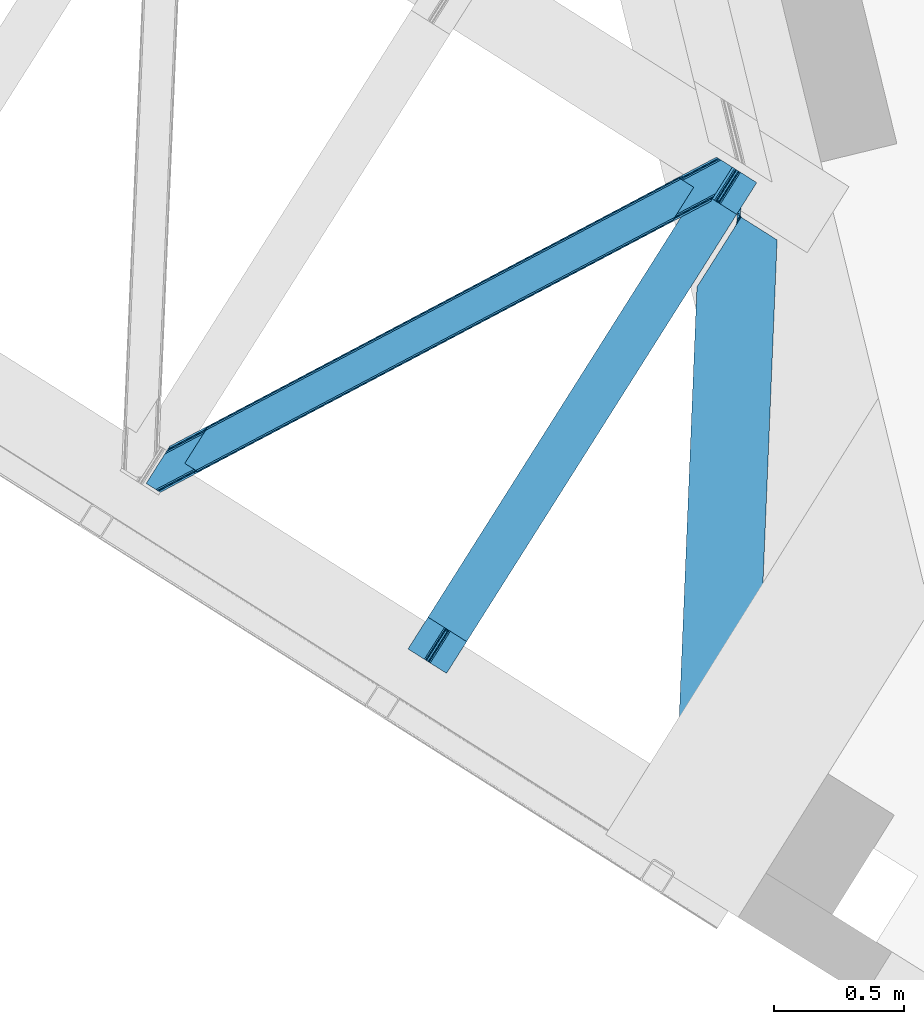
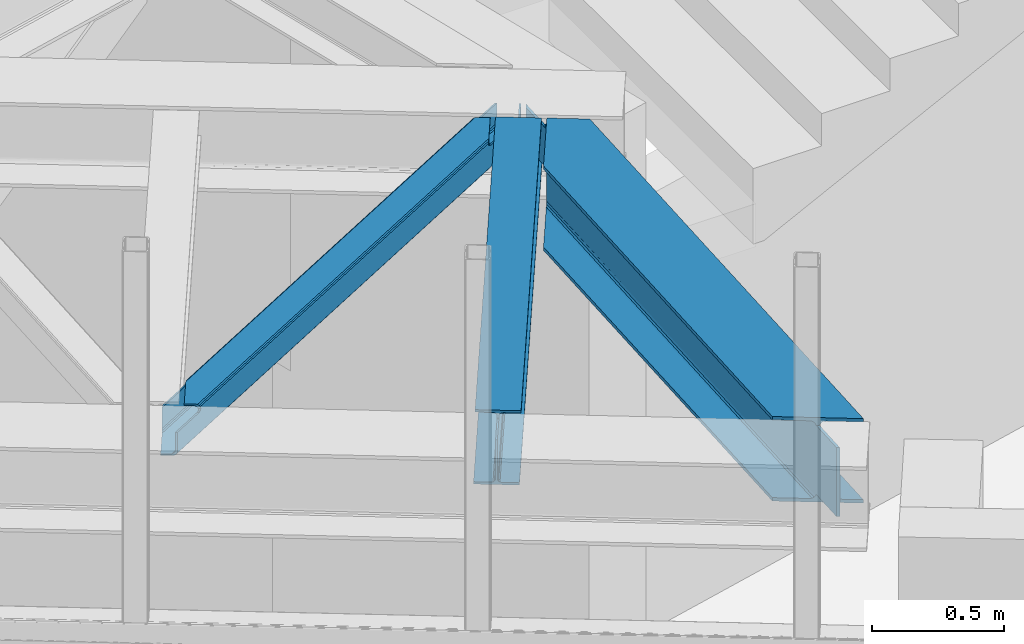
# One storey, part 50 of 66: 2 beams, 1 member.
"""IFC4 building model written with IfcOpenShell, lengths in millimetres."""

from ifc_helpers import new_model, entity, si_unit, converted_unit, derived_unit, direction, frame, origin, place, context, subcontext, project, spatial, triangles, type_object, element, save


model = new_model("IFC4")

# Units and contexts
model_context = context("Model", 3, precision=0.01, world=origin(), true_north=direction((6.12303176911189e-17, 1.0)))
plan_context = context("Plan", 3, precision=0.01, world=origin(), true_north=direction((6.12303176911189e-17, 1.0)))
body_context = subcontext(model_context, "Body", "Model", "MODEL_VIEW")
ifc_project = project(units=[si_unit("LENGTHUNIT", "METRE", prefix="MILLI"), si_unit("AREAUNIT", "SQUARE_METRE"), si_unit("VOLUMEUNIT", "CUBIC_METRE"), converted_unit("PLANEANGLEUNIT", "DEGREE", entity("IfcRatioMeasure", 0.0174532925199433), si_unit("PLANEANGLEUNIT", "RADIAN"), dimensions=[0, 0, 0, 0, 0, 0, 0]), si_unit("MASSUNIT", "GRAM", prefix="KILO"), derived_unit("MASSDENSITYUNIT", [(si_unit("MASSUNIT", "GRAM", prefix="KILO"), 1), (si_unit("LENGTHUNIT", "METRE"), -3)]), derived_unit("MOMENTOFINERTIAUNIT", [(si_unit("LENGTHUNIT", "METRE"), 4)]), si_unit("TIMEUNIT", "SECOND"), si_unit("FREQUENCYUNIT", "HERTZ"), si_unit("THERMODYNAMICTEMPERATUREUNIT", "DEGREE_CELSIUS"), derived_unit("THERMALTRANSMITTANCEUNIT", [(si_unit("MASSUNIT", "GRAM", prefix="KILO"), 1), (si_unit("THERMODYNAMICTEMPERATUREUNIT", "KELVIN"), -1), (si_unit("TIMEUNIT", "SECOND"), -3)]), derived_unit("VOLUMETRICFLOWRATEUNIT", [(si_unit("LENGTHUNIT", "METRE"), 3), (si_unit("TIMEUNIT", "SECOND"), -1)]), derived_unit("MASSFLOWRATEUNIT", [(si_unit("MASSUNIT", "GRAM", prefix="KILO"), 1), (si_unit("TIMEUNIT", "SECOND"), -1)]), derived_unit("ROTATIONALFREQUENCYUNIT", [(si_unit("TIMEUNIT", "SECOND"), -1)]), si_unit("ELECTRICCURRENTUNIT", "AMPERE"), si_unit("ELECTRICVOLTAGEUNIT", "VOLT"), si_unit("POWERUNIT", "WATT"), si_unit("FORCEUNIT", "NEWTON", prefix="KILO"), si_unit("ILLUMINANCEUNIT", "LUX"), si_unit("LUMINOUSFLUXUNIT", "LUMEN"), si_unit("LUMINOUSINTENSITYUNIT", "CANDELA"), derived_unit("USERDEFINED", [(si_unit("MASSUNIT", "GRAM", prefix="KILO"), -1), (si_unit("LENGTHUNIT", "METRE"), -2), (si_unit("TIMEUNIT", "SECOND"), 3), (si_unit("LUMINOUSFLUXUNIT", "LUMEN"), 1)]), derived_unit("LINEARVELOCITYUNIT", [(si_unit("LENGTHUNIT", "METRE"), 1), (si_unit("TIMEUNIT", "SECOND"), -1)]), si_unit("PRESSUREUNIT", "PASCAL"), derived_unit("USERDEFINED", [(si_unit("LENGTHUNIT", "METRE"), -2), (si_unit("MASSUNIT", "GRAM", prefix="KILO"), 1), (si_unit("TIMEUNIT", "SECOND"), -2)]), derived_unit("LINEARFORCEUNIT", [(si_unit("MASSUNIT", "GRAM", prefix="KILO"), 1), (si_unit("LENGTHUNIT", "METRE"), 1), (si_unit("TIMEUNIT", "SECOND"), -2), (si_unit("LENGTHUNIT", "METRE"), -1)]), derived_unit("PLANARFORCEUNIT", [(si_unit("MASSUNIT", "GRAM", prefix="KILO"), 1), (si_unit("LENGTHUNIT", "METRE"), 1), (si_unit("TIMEUNIT", "SECOND"), -2), (si_unit("LENGTHUNIT", "METRE"), -2)])], contexts=[model_context, plan_context])

# Site, building, storey
site_placement = place(None, origin())
site = spatial("IfcSite", under=ifc_project, at=site_placement, CompositionType="ELEMENT")
building_placement = place(site_placement, origin())
building = spatial("IfcBuilding", under=site, at=building_placement, CompositionType="ELEMENT")
storey_placement = place(building_placement, frame((0.0, 0.0, 19800.0)))
storey = spatial("IfcBuildingStorey", under=building, at=storey_placement, Name="06", CompositionType="ELEMENT", Elevation=19800.0)

# Beams
beam_type_1 = type_object("IfcBeamType", PredefinedType="BEAM")
beam_1_placement = place(storey_placement, frame((-1267.77, 13575.97, 3864.0)))
element("IfcBeam", 1, at=beam_1_placement, inside=storey, type_object=beam_type_1, ObjectType="Steel Beam", PredefinedType="BEAM", context=body_context, shape_type="Tessellation", body=[
    triangles([(1113.74242901802, 1855.23675842285, 232.99973144531), (1171.22194197178, 1818.90060424805, 232.99973144531), (134.557775115967, 179.105346679688, 232.99973144531), (77.078289413452, 215.441500854493, 232.99973144531), (1113.74242901802, 1855.23675842285, 244.001385498046), (77.078289413452, 215.441500854493, 244.001385498046), (1261.66156323999, 1761.72269897461, 244.001385498046), (225.001891136169, 121.928604125977, 244.001385498046), (1261.66156323999, 1761.72269897461, 232.99973144531), (225.001891136169, 121.928604125977, 232.99973144531), (1204.18659954071, 1798.06001586914, 232.99973144531), (167.522478103638, 158.264758300782, 232.99973144531), (1199.00899951458, 1801.33190917969, 231.783526611329), (1176.39499104023, 1815.62754821777, 231.783526611329), (1191.69133661985, 1805.95953369141, 223.123590087889), (1180.78569324017, 1812.85446166992, 228.313970947263), (1194.62281647921, 1804.10615844727, 228.313970947263), (1190.76869580746, 1806.54321899414, 219.000585937498), (1184.63980937004, 1810.41740112305, 219.000585937498), (1183.71717309952, 1811.00108642578, 223.123590087889), (157.958672332764, 164.310900878907, 228.313970947263), (162.344887161255, 161.536651611328, 231.783526611329), (144.121508216858, 173.06036682129, 228.313970947263), (139.730860519409, 175.832290649414, 231.783526611329), (154.104547119141, 166.747961425781, 219.000585937498), (155.027165222168, 166.164276123047, 223.123590087889), (147.975706100464, 170.622143554687, 219.000585937498), (147.053015327454, 171.206991577148, 223.123590087889), (147.982028388977, 170.400064086914, 217.00070800781), (1184.84340341091, 1810.50576782227, 217.00070800781), (1190.76235535145, 1806.76529846191, 217.00070800781), (153.900925827026, 166.659594726563, 217.00070800781), (1191.11113493443, 1807.31759033203, 214.791540527342), (1185.19218299389, 1811.05805969238, 214.791540527342), (1192.38168329, 1809.33258361816, 211.221990966795), (1186.46725051403, 1813.07421569824, 211.221990966795), (1194.28882523775, 1812.34867858887, 208.838415527342), (1188.37442879677, 1816.09031066895, 208.838415527342), (1196.54243041277, 1815.90776367188, 208.001257324217), (1190.62348301411, 1819.64823303223, 208.001257324217), (153.55218257904, 166.107302856446, 214.791540527342), (147.633212471008, 169.847772216797, 214.791540527342), (152.277042388916, 164.092309570313, 211.221990966795), (146.358217620849, 167.831616210937, 211.221990966795), (150.369964027405, 161.075051879883, 208.838415527342), (144.450993919372, 164.815521240234, 208.838415527342), (148.120828056335, 157.517129516602, 208.001257324217), (142.201930618286, 161.257598876953, 208.001257324217), (1267.74426928712, 1928.53809814453, 208.001257324217), (1261.82531823367, 1932.27856750488, 208.001257324217), (76.9144912719726, 44.8867950439453, 208.001257324217), (71.0000993728638, 48.6272644042965, 208.001257324217), (1261.82531823367, 1932.27856750488, 27.0006774902322), (71.0000993728638, 48.6272644042965, 27.0006774902322), (1267.74426928712, 1928.53809814453, 27.0006774902322), (76.9144912719726, 44.8867950439453, 27.0006774902322), (1253.4777905345, 1937.55615234375, 12.2178588867173), (1248.30474373698, 1940.82920837402, 10.9993286132813), (57.4749801635742, 57.1767425537109, 10.9993286132813), (62.6525711059569, 53.9060119628903, 12.2178588867173), (1257.86397470534, 1934.78190307617, 15.6874145507791), (67.0387859344482, 51.1317626953132, 15.6874145507791), (1260.8000060901, 1932.92969055176, 20.877795410157), (69.970220375061, 49.2783874511715, 20.877795410157), (1190.82522397041, 1977.16536254883, 10.9993286132813), (0.0, 93.5140594482418, 10.9993286132813), (1190.82522397041, 1977.16536254883, 0.0), (0.0, 93.5140594482418, 0.0), (1338.74436103106, 1883.65130310059, 0.0), (147.91916885376, 0.0, 0.0), (85.2665977478027, 39.6092102050789, 12.2178588867173), (80.8758047103881, 42.3822967529304, 15.6874145507791), (77.9443702697754, 44.2356719970703, 20.877795410157), (90.4396104812622, 36.3373168945309, 10.9993286132813), (147.91916885376, 0.0, 10.9993286132813), (1271.70561341867, 1926.03359985352, 15.6874145507791), (1276.09179787338, 1923.25935058594, 12.2178588867173), (1281.26939676404, 1919.98861999512, 10.9993286132813), (1338.74436103106, 1883.65130310059, 10.9993286132813), (1268.77413476575, 1927.88697509766, 20.877795410157)], [[1, 2, 3], [3, 4, 1], [5, 1, 4], [4, 6, 5], [7, 5, 8], [6, 8, 5], [9, 7, 10], [8, 10, 7], [11, 9, 10], [10, 12, 11], [11, 13, 14], [15, 16, 17], [13, 17, 16], [15, 18, 19], [7, 11, 5], [11, 7, 9], [2, 11, 14], [16, 15, 20], [19, 20, 15], [16, 14, 13], [2, 5, 11], [5, 2, 1], [21, 22, 23], [12, 8, 6], [10, 8, 12], [22, 12, 24], [25, 26, 27], [26, 21, 23], [23, 22, 24], [6, 3, 12], [3, 24, 12], [6, 4, 3], [23, 28, 26], [28, 27, 26], [19, 29, 27], [27, 20, 19], [19, 30, 29], [27, 28, 20], [16, 20, 23], [28, 23, 20], [14, 16, 23], [23, 24, 14], [2, 14, 3], [24, 3, 14], [25, 31, 18], [18, 26, 25], [18, 15, 26], [25, 32, 31], [15, 17, 26], [21, 26, 17], [17, 13, 22], [22, 21, 17], [13, 11, 12], [12, 22, 13], [31, 33, 34], [34, 30, 31], [18, 31, 30], [30, 19, 18], [33, 35, 34], [36, 34, 35], [35, 37, 38], [38, 36, 35], [37, 39, 38], [40, 38, 39], [41, 32, 42], [29, 42, 32], [32, 25, 27], [27, 29, 32], [43, 41, 42], [42, 44, 43], [45, 43, 46], [44, 46, 43], [47, 45, 46], [46, 48, 47], [49, 50, 39], [40, 39, 50], [47, 48, 51], [52, 51, 48], [36, 53, 54], [38, 53, 36], [50, 53, 40], [38, 40, 53], [30, 34, 42], [34, 36, 42], [44, 36, 54], [54, 46, 44], [48, 46, 54], [54, 52, 48], [44, 42, 36], [42, 29, 30], [55, 35, 56], [33, 41, 35], [37, 35, 55], [33, 31, 32], [55, 39, 37], [39, 55, 49], [56, 35, 43], [43, 35, 41], [32, 41, 33], [43, 45, 56], [47, 56, 45], [56, 47, 51], [57, 58, 59], [59, 60, 57], [61, 57, 62], [60, 62, 57], [63, 61, 62], [62, 64, 63], [53, 63, 54], [64, 54, 63], [58, 65, 66], [66, 59, 58], [65, 67, 66], [68, 66, 67], [67, 69, 68], [70, 68, 69], [71, 72, 60], [56, 64, 73], [72, 73, 62], [56, 51, 54], [74, 68, 70], [70, 75, 74], [74, 71, 59], [60, 72, 62], [64, 56, 54], [52, 54, 51], [64, 62, 73], [68, 74, 59], [60, 59, 71], [66, 68, 59], [76, 77, 57], [78, 69, 67], [79, 69, 78], [77, 78, 58], [55, 80, 63], [80, 76, 61], [49, 55, 53], [61, 76, 57], [67, 58, 78], [58, 57, 77], [67, 65, 58], [63, 53, 55], [53, 50, 49], [61, 63, 80], [80, 55, 73], [56, 73, 55], [76, 80, 73], [73, 72, 76], [77, 76, 71], [72, 71, 76], [78, 77, 71], [71, 74, 78], [79, 78, 75], [74, 75, 78], [69, 79, 70], [75, 70, 79]]),
])
beam_type_2 = type_object("IfcBeamType", PredefinedType="BEAM")
beam_2_placement = place(storey_placement, frame((-235.75, 12925.28, 3716.0)))
element("IfcBeam", 2, at=beam_2_placement, inside=storey, type_object=beam_type_2, ObjectType="Steel Beam", PredefinedType="BEAM", context=body_context, shape_type="Tessellation", body=[
    triangles([(233.281526336074, 2423.1276763916, 356.001525878906), (244.678622616827, 2415.92462768555, 356.001525878906), (238.341486717761, 2545.92599487305, 356.001525878906), (250.747194671631, 2565.55502929687, 356.001525878906), (245.781376549602, 2403.50561828613, 362.41043701172), (244.023252917826, 2403.74630126953, 364.221954345703), (245.537573298812, 2402.36499023438, 367.000854492188), (242.53565749079, 2405.33225097656, 362.817388916017), (244.82996353358, 2406.62286987305, 359.222259521484), (241.500046648085, 2406.43916015625, 361.83837890625), (238.207450908422, 2409.10643920898, 361.001220703125), (232.385556542873, 2414.48983154297, 359.222259521484), (231.81794237718, 2413.14689025879, 361.001220703125), (244.56884098202, 2411.01329956055, 356.838684082031), (232.990733709186, 2418.33145751953, 356.838684082031), (248.213948589563, 2400.67439575195, 367.000854492188), (231.194143527746, 2398.01176757813, 361.001220703125), (245.848223850131, 2402.17081604004, 367.79150390625), (229.080534236133, 2380.1116973877, 364.221954345703), (226.37978554666, 2371.37618408203, 367.79150390625), (246.55568203032, 2401.72316894531, 372.000549316406), (224.501758146286, 2367.80779724121, 369.407684326172), (221.500491258502, 2362.09186706543, 372.000549316406), (230.523896920681, 2389.07626647949, 361.83837890625), (230.180002690852, 2386.93221130371, 362.408111572266), (265.525510007143, 2389.72971496582, 376.000305175781), (257.313895046711, 2394.92125854492, 374.325988769531), (246.55568203032, 2401.72316894531, 392.001654052736), (250.749615490437, 2399.07100524902, 369.042590332032), (384.774951267242, 2314.34245605469, 392.001654052736), (384.774951267242, 2314.34245605469, 376.000305175781), (292.630248641968, 77.4278320312496, 392.001654052736), (292.630248641968, 77.4278320312496, 376.000305175781), (173.385328817368, 152.816253662109, 376.000305175781), (77.0741108894348, 2133.64185791016, 392.001654052736), (0.0, 262.429330444336, 392.001654052736), (216.970907637477, 2354.92835083008, 374.325988769531), (207.956919550896, 2340.67108154297, 376.000305175781), (77.0741108894348, 2133.64185791016, 376.000305175781), (119.244928908348, 187.040908813477, 376.000305175781), (0.0, 262.429330444336, 376.000305175781), (158.208139300346, 162.40869140625, 369.556512451174), (165.173679792881, 158.008959960938, 374.325988769531), (134.422118425369, 177.448471069336, 369.556512451174), (127.461097097397, 181.849365234375, 374.325988769531), (152.011397266388, 166.325894165038, 356.001525878906), (153.556270265579, 165.350372314453, 362.419738769531), (140.61885137558, 173.531268310548, 356.001525878906), (139.073923873901, 174.50795288086, 362.419738769531), (133.766217327118, 7.20304870605469, 356.001525878906), (145.163350510597, 0.0, 356.001525878906), (133.856409859657, 7.14723815917932, 354.001647949219), (238.437992171198, 2546.08063659668, 354.001647949219), (250.747194671631, 2565.55502929687, 354.001647949219), (145.07314889431, 0.0558105468753638, 354.001647949219), (250.747194671631, 2565.55502929687, 179.000701904297), (238.437992171198, 2546.08063659668, 179.000701904297), (244.730604931712, 2419.42325134277, 179.000701904297), (232.416850054264, 2399.94769592285, 179.000701904297), (244.381695905328, 2410.99585876465, 178.163543701172), (232.072493688762, 2391.52146606445, 178.163543701172), (244.088522484899, 2403.85210876465, 175.777642822268), (231.77476760745, 2384.37655334473, 175.777642822268), (243.892482148111, 2399.07914428711, 172.210418701172), (231.578761618584, 2379.60358886719, 172.210418701172), (243.822449858487, 2397.40250244141, 168.001373291016), (231.508694413304, 2377.92694702148, 168.001373291016), (133.856409859657, 7.14723815917932, 38.0000061035171), (231.508694413304, 2377.92694702148, 38.0000061035171), (145.07314889431, 0.0558105468753638, 38.0000061035171), (243.822449858487, 2397.40250244141, 38.0000061035171), (145.163350510597, 0.0, 36.0001281738296), (133.766217327118, 7.20304870605469, 36.0001281738296), (152.011397266388, 166.325894165038, 36.0001281738296), (140.61885137558, 173.531268310548, 36.0001281738296), (229.720073233545, 2375.09223632813, 29.5819152832046), (139.073923873901, 174.50795288086, 29.5819152832046), (224.613497328758, 2367.01598510742, 22.4451416015654), (134.422118425369, 177.448471069336, 22.4451416015654), (216.970907637477, 2354.92835083008, 17.6756652832046), (127.461097097397, 181.849365234375, 17.6756652832046), (207.956919550896, 2340.67108154297, 16.0013488769546), (119.244928908348, 187.040908813477, 16.0013488769546), (0.0, 262.429330444336, 16.0013488769546), (77.0741108894348, 2133.64185791016, 16.0013488769546), (77.0741108894348, 2133.64185791016, 0.0), (0.0, 262.429330444336, 0.0), (246.55568203032, 2401.72316894531, 0.0), (246.55568203032, 2401.72316894531, 25.0007995605483), (245.615590202808, 2400.23837585449, 29.5819152832046), (246.704236507416, 2401.95920104981, 27.4587890625007), (248.213948589563, 2400.67439575195, 25.0007995605483), (257.313895046711, 2394.92125854492, 17.6756652832046), (250.749615490437, 2399.07100524902, 22.9590637207039), (158.208139300346, 162.40869140625, 22.4451416015654), (153.556270265579, 165.350372314453, 29.5819152832046), (165.173679792881, 158.008959960938, 17.6756652832046), (265.525510007143, 2389.72971496582, 16.0013488769546), (173.385328817368, 152.816253662109, 16.0013488769546), (292.630248641968, 77.4278320312496, 0.0), (292.630248641968, 77.4278320312496, 16.0013488769546), (384.774951267242, 2314.34245605469, 0.0), (384.774951267242, 2314.34245605469, 16.0013488769546)], [[1, 2, 3], [4, 3, 2], [5, 6, 7], [5, 8, 6], [9, 10, 8], [11, 9, 12], [12, 13, 11], [11, 10, 9], [14, 2, 15], [1, 15, 2], [9, 14, 12], [15, 12, 14], [8, 5, 9], [7, 16, 5], [11, 13, 17], [18, 7, 19], [19, 20, 18], [21, 20, 22], [20, 21, 18], [22, 23, 21], [7, 6, 19], [6, 8, 24], [8, 10, 24], [6, 25, 19], [25, 6, 24], [10, 11, 17], [17, 24, 10], [26, 27, 28], [27, 29, 21], [30, 26, 28], [26, 30, 31], [21, 28, 27], [16, 18, 21], [7, 18, 16], [16, 21, 29], [31, 30, 32], [32, 33, 31], [33, 34, 31], [26, 31, 34], [35, 32, 30], [35, 36, 32], [30, 28, 35], [21, 23, 28], [28, 37, 38], [37, 28, 23], [38, 35, 28], [35, 38, 39], [40, 41, 39], [39, 38, 40], [35, 39, 36], [41, 36, 39], [42, 43, 44], [34, 32, 36], [33, 32, 34], [43, 34, 45], [46, 47, 48], [47, 42, 49], [44, 43, 45], [36, 40, 34], [40, 45, 34], [36, 41, 40], [44, 49, 42], [49, 48, 47], [50, 51, 46], [46, 48, 50], [44, 45, 37], [37, 23, 44], [49, 44, 22], [22, 20, 49], [20, 19, 49], [52, 15, 1], [1, 53, 52], [1, 3, 53], [52, 24, 17], [17, 12, 52], [24, 52, 48], [48, 25, 24], [17, 13, 12], [12, 15, 52], [48, 49, 25], [52, 50, 48], [19, 25, 49], [23, 22, 44], [38, 37, 45], [45, 40, 38], [27, 43, 42], [42, 5, 16], [5, 42, 47], [16, 29, 42], [47, 14, 9], [46, 54, 2], [2, 47, 46], [2, 14, 47], [54, 4, 2], [9, 5, 47], [54, 46, 55], [51, 55, 46], [42, 29, 27], [27, 26, 43], [34, 43, 26], [54, 56, 53], [4, 54, 53], [57, 53, 56], [53, 3, 4], [58, 59, 57], [57, 56, 58], [58, 60, 59], [61, 59, 60], [60, 62, 61], [63, 61, 62], [62, 64, 63], [65, 63, 64], [64, 66, 65], [67, 65, 66], [53, 63, 65], [61, 63, 53], [53, 59, 61], [59, 53, 57], [67, 68, 52], [68, 67, 69], [65, 52, 53], [52, 65, 67], [62, 54, 64], [58, 54, 60], [58, 56, 54], [62, 60, 54], [55, 64, 54], [66, 55, 70], [55, 66, 64], [70, 71, 66], [70, 55, 68], [55, 51, 52], [72, 70, 73], [68, 55, 52], [50, 52, 51], [68, 73, 70], [72, 73, 74], [75, 74, 73], [75, 69, 76], [76, 77, 75], [69, 75, 68], [73, 68, 75], [76, 78, 77], [79, 77, 78], [78, 80, 79], [81, 79, 80], [80, 82, 81], [83, 81, 82], [84, 83, 85], [82, 85, 83], [85, 86, 84], [87, 84, 86], [88, 89, 76], [76, 90, 71], [67, 69, 71], [67, 71, 66], [89, 91, 90], [89, 90, 76], [82, 88, 80], [78, 88, 76], [69, 76, 71], [78, 80, 88], [82, 86, 88], [86, 82, 85], [92, 89, 91], [93, 94, 95], [92, 91, 90], [96, 95, 94], [94, 92, 96], [71, 70, 74], [74, 90, 71], [74, 96, 90], [70, 72, 74], [90, 96, 92], [95, 97, 93], [98, 93, 97], [97, 99, 98], [99, 97, 81], [96, 77, 95], [97, 95, 79], [96, 74, 75], [100, 99, 87], [99, 100, 101], [83, 99, 81], [79, 95, 77], [75, 77, 96], [79, 81, 97], [83, 87, 99], [87, 83, 84], [93, 98, 88], [102, 98, 103], [98, 102, 88], [94, 88, 89], [88, 94, 93], [89, 92, 94], [100, 86, 102], [86, 100, 87], [88, 102, 86], [99, 101, 103], [103, 98, 99], [102, 103, 100], [101, 100, 103]]),
])

# Member
member_type = type_object("IfcMemberType", PredefinedType="BRACE")
member_placement = place(storey_placement, frame((-2272.78, 14270.52, 3964.0)))
element("IfcMember", 3, at=member_placement, inside=storey, type_object=member_type, ObjectType="Steel Horizontal Brace", PredefinedType="BRACE", context=body_context, shape_type="Tessellation", body=[
    triangles([(2166.61486344337, 1116.62719116211, 113.0000793457), (2173.80174307823, 1127.99161376953, 113.0000793457), (2044.4205051899, 1059.94925537109, 113.0000793457), (2036.90270462036, 1048.05812072754, 113.0000793457), (2029.42218375206, 1044.1037109375, 113.837237548825), (2032.01686549187, 1053.39151611328, 115.49992675781), (2030.77495365143, 1052.79155273437, 116.285925292967), (2036.94003882408, 1055.99484558105, 113.837237548825), (2026.93752436638, 1051.31141052246, 119.790362548825), (2018.84619412422, 1038.51219177246, 119.790362548825), (2023.08254528046, 1040.75158996582, 116.220812988278), (2028.56100811958, 1051.72068786621, 117.688165283202), (2026.56859703064, 1052.01950683594, 122.19719238281), (2017.54004201889, 1037.82153625488, 122.499499511716), (2017.42678585053, 1037.83432617187, 123.999407958981), (2027.24235677719, 1053.36012268066, 123.999407958981), (200.000582885742, 78.5370666503895, 129.196765136716), (201.301375579834, 77.717349243163, 122.499499511716), (2018.78793096542, 1039.9888458252, 129.196765136716), (2022.86099267006, 1046.4326385498, 134.873162841795), (196.304878234863, 80.8741333007802, 134.873162841795), (2028.95898528099, 1056.07856140137, 138.668280029295), (190.775273895264, 84.3727569580078, 138.668280029295), (2036.15227804184, 1067.45577392578, 139.998431396481), (184.250090789795, 88.4980865478501, 139.998431396481), (193.497927474975, 81.5101409912095, 114.86740722656), (194.136696624756, 82.2473052978512, 118.999713134763), (192.620655441284, 83.2042236328125, 121.887908935547), (189.485236358642, 85.1866607666016, 127.873590087889), (2030.37881140709, 1058.32493591309, 127.873590087889), (2043.67013311386, 1079.34690856934, 132.998858642575), (2036.47684035301, 1067.96969604492, 131.666381835938), (177.425943374634, 92.8094512939442, 132.998858642575), (183.951126480103, 88.6841217041001, 131.666381835938), (201.301375579834, 77.717349243163, 118.999713134763), (148.082821655273, 111.360644531249, 139.998431396481), (148.082821655273, 111.360644531249, 132.998858642575), (2101.84745049477, 1171.37268676758, 139.998431396481), (2101.84745049477, 1171.37268676758, 132.998858642575), (2059.13757562637, 1198.37336425781, 139.998431396481), (220.991888809204, 226.688488769531, 139.998431396481), (2065.9571993351, 1194.06083679199, 132.998858642575), (213.474033737183, 214.797354125976, 132.998858642575), (226.76537361145, 235.819326782226, 127.873590087889), (228.185199737549, 238.066864013672, 138.668280029295), (220.667344665527, 226.17456665039, 131.666381835938), (234.283228683472, 247.711624145508, 134.873162841795), (229.901810073852, 240.784140014648, 123.999407958981), (238.35623588562, 254.155416870117, 129.196765136716), (239.717344665527, 256.309936523438, 123.999407958981), (2043.38265066147, 1208.33322143555, 129.196765136716), (2042.08625450134, 1209.1541015625, 122.499499511716), (239.604124832153, 256.322726440429, 122.499499511716), (2052.6124288559, 1202.49985656738, 138.668280029295), (2047.07826447487, 1205.99615478516, 134.873162841795), (2053.90241189003, 1201.68479003906, 127.873590087889), (2059.43205256462, 1198.18732910156, 131.666381835938), (2050.76254177094, 1203.66722717285, 121.887908935547), (2049.25095162392, 1204.62414550781, 118.999713134763), (2042.08625450134, 1209.1541015625, 118.999713134763), (230.575606155395, 242.124755859375, 122.19719238281), (2049.88982977867, 1205.36130981445, 114.86740722656), (228.587500762939, 242.424737548827, 117.690490722656), (226.52614402771, 241.474795532225, 116.220812988278), (230.206587982178, 242.832852172851, 119.790362548825), (225.127246856689, 240.752746582031, 115.49992675781), (238.297954559326, 255.632070922851, 119.790362548825), (234.061585235596, 253.392672729491, 116.220812988278), (227.722001266479, 250.040551757811, 113.837237548825), (220.204146194458, 238.149417114257, 113.837237548825), (220.241498565674, 246.087304687499, 113.0000793457), (212.723643493652, 234.195007324219, 113.0000793457), (199.660342025757, 76.8499603271484, 115.109252929688), (198.014802932739, 75.9802459716793, 111.22111816406), (190.089123916626, 71.7909667968743, 108.000384521481), (194.054288864136, 73.8861877441395, 109.609588623047), (187.230141448974, 78.1975524902336, 109.609588623047), (183.269482040405, 76.1034942626939, 108.000384521481), (191.195161056518, 80.2927734374989, 111.22111816406), (2045.36841244698, 1210.89004211426, 111.22111816406), (2043.72734255791, 1210.02265319824, 115.109252929688), (2052.1880361557, 1206.57751464844, 111.22111816406), (2056.15312843323, 1208.6727355957, 109.609588623047), (2049.3335047245, 1212.98526306152, 109.609588623047), (2060.11818437576, 1210.7691192627, 108.000384521481), (2053.2940369606, 1215.08048400879, 108.000384521481), (54.2830238342285, 0.0, 108.000384521481), (47.4635272979735, 4.31252746581958, 108.000384521481), (2166.61486344337, 1116.62719116211, 17.4989318847656), (54.2830238342285, 0.0, 17.4989318847656), (2032.0435353756, 1053.34151916504, 115.49992675781), (2174.14860599041, 1128.49274597168, 24.4985046386719), (191.196323776245, 80.2881225585934, 111.22111816406), (2173.68541660309, 1128.21253051758, 113.0000793457), (2044.44708423615, 1059.89925842285, 113.0000793457), (2174.16452071667, 1128.46716613769, 112.135015869138), (2036.96659970284, 1055.94484863281, 113.837237548825), (47.4478305816651, 4.3381072998036, 24.4985046386719), (183.2703540802, 76.1000061035156, 108.000384521481), (187.235664367676, 78.1940643310536, 109.609588623047), (47.4633819580076, 4.31369018554688, 108.000384521481), (193.499235534668, 81.5043273925767, 114.86740722656), (2185.41397941113, 1146.35793457031, 0.0), (2178.22067756653, 1134.9807220459, 1.33247680663771), (37.2317390441895, 10.7807373046871, 0.0), (43.7569221496583, 6.65540771484302, 1.33247680663771), (2172.12263953686, 1125.33479919434, 5.12526855468604), (49.2910320281981, 3.15910949706995, 5.12526855468604), (2168.04959599972, 1118.89100646973, 10.8016662597656), (52.9867366790772, 0.822042846679324, 10.8016662597656), (2174.1327185154, 1128.51832580566, 24.4985046386719), (2175.56744198799, 1130.78330383301, 17.8035644531228), (46.1670948028564, 5.13457031249891, 17.8035644531228), (47.4635272979735, 4.31252746581958, 24.4985046386719), (2179.64049460888, 1137.22709655762, 12.1248413085923), (42.4668846130371, 7.47047424316406, 12.1248413085923), (2185.7385235548, 1146.87185668945, 8.33204956054396), (36.9372802734374, 10.9679351806626, 8.33204956054396), (2192.93179814816, 1158.25023193359, 6.99957275390625), (30.4120971679686, 15.0932647705067, 6.99957275390625), (2249.93033573627, 1248.41333312988, 6.99957275390625), (2249.93033573627, 1248.41333312988, 0.0), (2174.1327185154, 1128.51832580566, 112.135015869138), (2195.92426629066, 1282.55892333984, 108.000384521481), (2189.1001188755, 1286.87028808594, 108.000384521481), (0.0, 34.3199981689449, 6.99957275390625), (0.0, 34.3199981689449, 0.0), (90.5293579101563, 177.517071533202, 113.0000793457), (83.0115028381347, 165.625936889648, 113.0000793457), (2189.1001188755, 1286.87028808594, 17.4989318847656), (90.5293579101563, 177.517071533202, 17.4989318847656), (2206.15144000053, 1276.08955078125, 0.0), (71.730214691162, 147.786328124999, 0.0), (2190.40098423958, 1286.05057067871, 10.8016662597656), (89.0945617675779, 175.253256225586, 10.8016662597656), (2194.09663438797, 1283.71350402832, 5.12526855468604), (85.0214092254637, 168.809463500977, 5.12526855468604), (2199.62629323006, 1280.21488037109, 1.33247680663771), (78.9233802795411, 159.163540649413, 1.33247680663771), (2200.91626263857, 1279.4009765625, 12.1248413085923), (2212.97554653883, 1271.77818603516, 6.99957275390625), (2206.45043610334, 1275.903515625, 8.33204956054396), (2195.92426629066, 1282.55892333984, 24.4985046386719), (2197.2206079483, 1281.73804321289, 17.8035644531228), (83.0115028381347, 165.625936889648, 24.4985046386719), (81.5767066955564, 163.360958862304, 17.8035644531228), (77.503699493408, 156.917166137695, 12.1248413085923), (64.2123596191404, 135.894030761718, 6.99957275390625), (71.4056705474854, 147.272406005859, 8.33204956054396)], [[1, 2, 3], [3, 4, 1], [5, 6, 7], [5, 8, 6], [9, 10, 11], [11, 7, 12], [13, 14, 10], [13, 15, 14], [10, 9, 13], [13, 16, 15], [11, 12, 9], [7, 11, 5], [3, 8, 4], [5, 4, 8], [15, 17, 18], [18, 14, 15], [15, 19, 17], [19, 20, 21], [21, 17, 19], [20, 22, 23], [23, 21, 20], [22, 24, 25], [25, 23, 22], [26, 9, 12], [7, 6, 26], [26, 12, 7], [9, 26, 27], [27, 13, 9], [27, 28, 13], [29, 30, 16], [16, 28, 29], [16, 13, 28], [31, 32, 33], [34, 33, 32], [32, 30, 34], [29, 34, 30], [21, 29, 23], [28, 17, 18], [18, 35, 27], [27, 28, 18], [29, 17, 28], [21, 17, 29], [34, 25, 23], [23, 29, 34], [34, 33, 25], [33, 36, 25], [37, 36, 33], [32, 22, 30], [38, 31, 39], [31, 38, 24], [32, 24, 22], [32, 31, 24], [20, 16, 30], [22, 20, 30], [16, 20, 19], [15, 16, 19], [24, 40, 41], [24, 38, 40], [41, 25, 24], [36, 25, 41], [42, 31, 43], [31, 42, 39], [33, 43, 31], [37, 43, 33], [44, 45, 46], [47, 48, 49], [44, 47, 45], [49, 48, 50], [47, 44, 48], [46, 45, 41], [36, 43, 41], [37, 43, 36], [43, 46, 41], [50, 51, 52], [52, 53, 50], [40, 54, 45], [45, 41, 40], [54, 55, 47], [47, 45, 54], [55, 51, 49], [49, 47, 55], [50, 49, 51], [56, 54, 55], [39, 38, 42], [38, 40, 42], [54, 57, 40], [56, 57, 54], [57, 42, 40], [51, 58, 56], [55, 51, 56], [58, 51, 52], [52, 59, 58], [52, 60, 59], [56, 44, 48], [48, 58, 56], [48, 61, 58], [62, 63, 64], [62, 65, 63], [64, 66, 62], [65, 62, 59], [59, 61, 65], [59, 58, 61], [56, 57, 44], [46, 44, 57], [57, 42, 46], [43, 46, 42], [61, 53, 67], [61, 50, 53], [67, 65, 61], [65, 67, 68], [68, 64, 63], [69, 66, 64], [69, 70, 66], [69, 71, 70], [72, 70, 71], [64, 68, 69], [68, 63, 65], [61, 48, 50], [27, 26, 73], [73, 35, 27], [74, 73, 26], [75, 76, 77], [77, 78, 75], [76, 74, 79], [79, 77, 76], [26, 79, 74], [80, 81, 62], [59, 62, 81], [81, 60, 59], [62, 82, 80], [82, 83, 84], [84, 80, 82], [83, 85, 86], [86, 84, 83], [75, 78, 87], [88, 87, 78], [11, 74, 89], [11, 10, 74], [14, 74, 10], [35, 73, 14], [35, 14, 18], [5, 11, 89], [89, 1, 4], [4, 5, 89], [90, 89, 74], [74, 14, 73], [74, 76, 90], [75, 90, 76], [90, 75, 87], [91, 92, 93], [94, 92, 95], [94, 96, 92], [91, 97, 92], [97, 95, 92], [93, 92, 98], [98, 99, 100], [98, 101, 99], [100, 93, 98], [93, 102, 91], [103, 104, 105], [106, 105, 104], [104, 107, 106], [108, 106, 107], [107, 109, 108], [110, 108, 109], [109, 89, 110], [90, 110, 89], [111, 112, 113], [113, 114, 111], [112, 115, 116], [116, 113, 112], [115, 117, 118], [118, 116, 115], [117, 119, 120], [120, 118, 117], [115, 107, 104], [115, 104, 117], [119, 117, 103], [112, 107, 115], [121, 119, 122], [103, 122, 119], [117, 104, 103], [109, 107, 112], [1, 89, 111], [111, 123, 1], [2, 1, 123], [109, 112, 89], [112, 111, 89], [124, 125, 85], [86, 85, 125], [110, 116, 108], [114, 90, 87], [87, 88, 114], [114, 113, 90], [113, 110, 90], [116, 110, 113], [106, 108, 116], [120, 105, 118], [116, 118, 106], [120, 126, 127], [118, 105, 106], [120, 127, 105], [72, 71, 128], [128, 129, 72], [80, 130, 131], [84, 130, 80], [125, 130, 86], [84, 86, 130], [60, 81, 53], [81, 80, 53], [52, 60, 53], [68, 80, 131], [131, 69, 68], [71, 69, 131], [131, 128, 71], [68, 67, 80], [67, 53, 80], [132, 103, 133], [103, 132, 122], [105, 133, 103], [127, 133, 105], [130, 134, 131], [135, 131, 134], [134, 136, 135], [137, 135, 136], [136, 138, 137], [139, 137, 138], [138, 132, 139], [133, 139, 132], [140, 138, 136], [121, 122, 141], [122, 132, 141], [138, 142, 132], [140, 142, 138], [142, 141, 132], [130, 143, 144], [134, 140, 136], [140, 134, 144], [134, 130, 144], [125, 143, 130], [125, 124, 143], [143, 82, 145], [83, 82, 143], [82, 62, 66], [143, 85, 83], [85, 143, 124], [145, 82, 66], [66, 70, 145], [72, 145, 70], [145, 72, 129], [137, 146, 147], [145, 131, 128], [128, 129, 145], [145, 146, 131], [146, 135, 131], [146, 137, 135], [139, 137, 147], [148, 133, 149], [147, 149, 139], [148, 126, 127], [149, 133, 139], [148, 127, 133], [119, 141, 148], [119, 121, 141], [148, 120, 119], [126, 120, 148], [141, 142, 149], [149, 148, 141], [142, 140, 147], [147, 149, 142], [140, 144, 146], [146, 147, 140], [144, 143, 145], [145, 146, 144]]),
])

save(model, "model.ifc")
